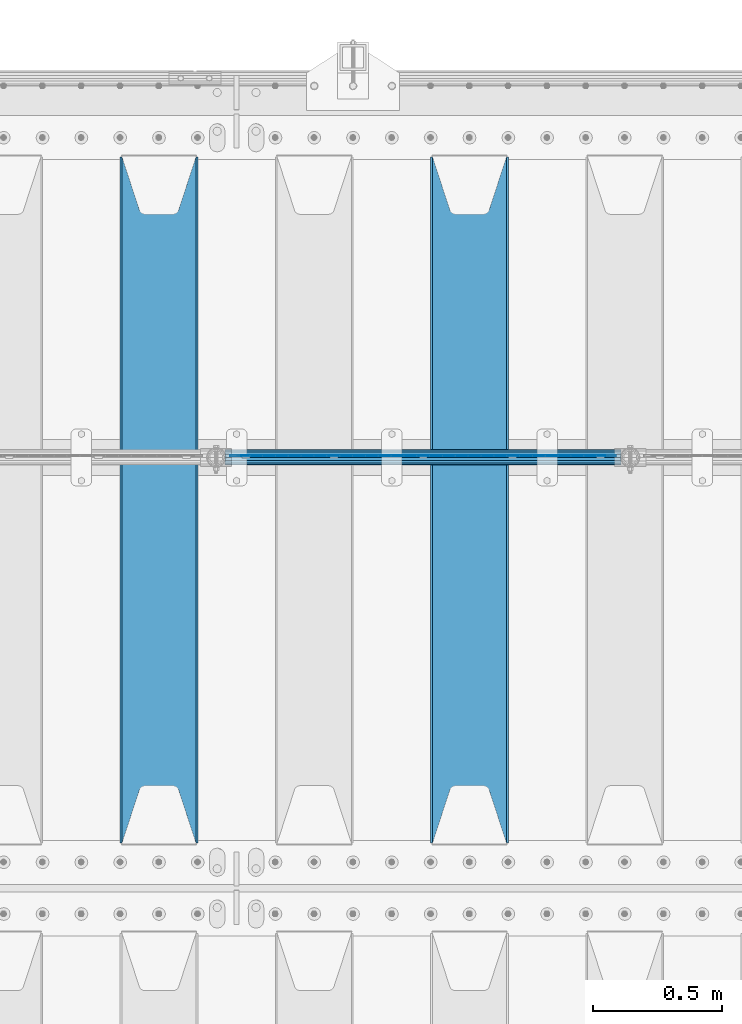
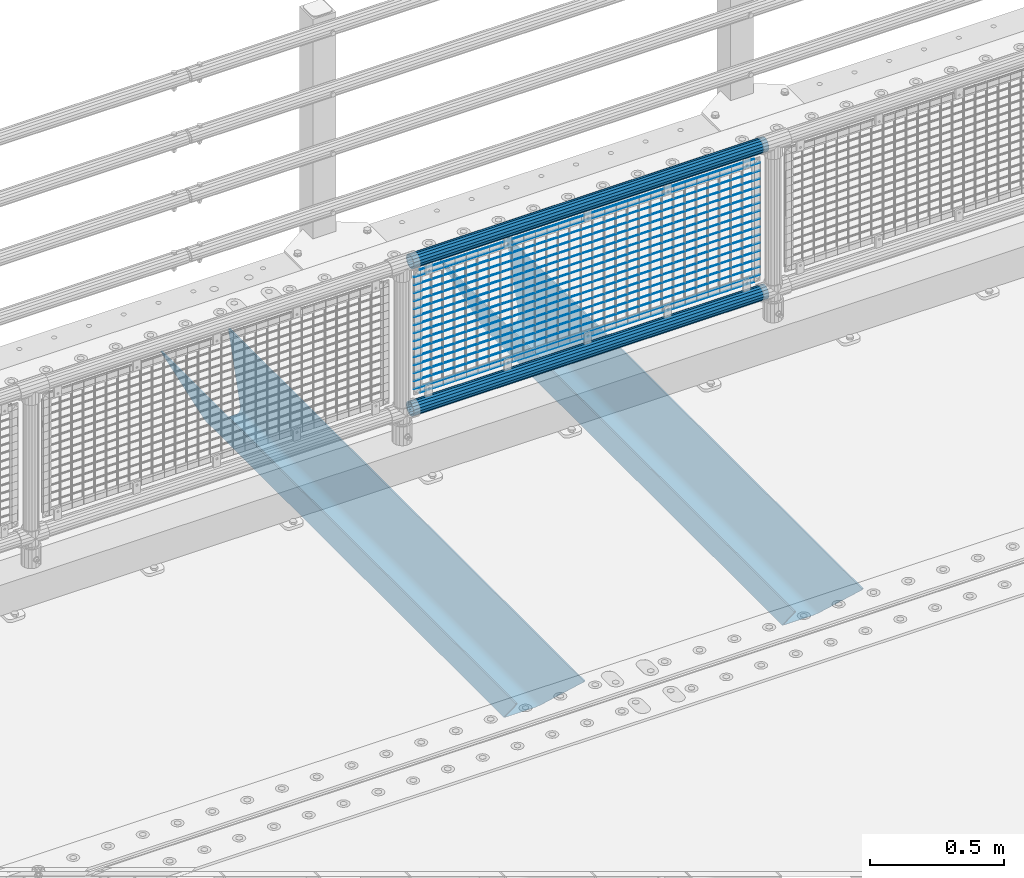
# One storey, part 119 of 257: 21 beams.
"""IFC2X3 building model written with IfcOpenShell, lengths in millimetres."""

from ifc_helpers import new_model, si_unit, frame, origin_with_axes, place, context, subcontext, project, spatial, faceted_brep, material, type_object, element, save


model = new_model("IFC2X3")

# Units and contexts
model_context = context("Model", 3, precision=1e-05, world=origin_with_axes())
body_context = subcontext(model_context, "Body", "Model", "MODEL_VIEW")
ifc_project = project(units=[si_unit("LENGTHUNIT", "METRE", prefix="MILLI"), si_unit("AREAUNIT", "SQUARE_METRE"), si_unit("VOLUMEUNIT", "CUBIC_METRE"), si_unit("MASSUNIT", "GRAM", prefix="KILO"), si_unit("TIMEUNIT", "SECOND"), si_unit("PLANEANGLEUNIT", "RADIAN"), si_unit("SOLIDANGLEUNIT", "STERADIAN"), si_unit("THERMODYNAMICTEMPERATUREUNIT", "DEGREE_CELSIUS"), si_unit("LUMINOUSINTENSITYUNIT", "LUMEN")], contexts=[model_context])

# Site, building, storey
site_placement = place(None, origin_with_axes())
site = spatial("IfcSite", under=ifc_project, at=site_placement, CompositionType="ELEMENT")
building_placement = place(site_placement, origin_with_axes())
building = spatial("IfcBuilding", under=site, at=building_placement, Name="Standard", CompositionType="ELEMENT")
storey_placement = place(building_placement, origin_with_axes())
storey = spatial("IfcBuildingStorey", under=building, at=storey_placement, Name="Undefined", CompositionType="ELEMENT", Elevation=0.0)

# Beams
ifc_material_1 = material(Name="STEEL/S355N")
beam_type_1 = type_object("IfcBeamType", PredefinedType="NOTDEFINED")
beam_1_placement = place(storey_placement, frame((48850.0, 9175.0, -115.0), z_axis=(0.0, 0.0, 1.0), x_axis=(0.0, 1.0, 0.0)))
element("IfcBeam", 1, at=beam_1_placement, inside=storey, type_object=beam_type_1, material=ifc_material_1, context=body_context, shape_type="Brep", body=[
    faceted_brep([(0.0, 150.0, 115.0), (0.0, 143.690000000002, 115.0), (2650.00000000297, 143.690000000002, 115.0), (2650.00000000297, 150.0, 115.0), (2650.00000000297, 142.059565218406, 110.0000000031), (2650.00000000297, 148.369565218403, 110.0000000031), (2441.90079219208, -80.1103600731149, -98.0992078077845), (2437.7588105432, -77.5672621345584, -102.241189456673), (2434.06523489746, -74.4080125315522, -105.934765102404), (2430.91086095089, -70.7102721255724, -109.089139048974), (2428.37322971128, -66.5649389910031, -111.626770288588), (2426.51472138055, -62.0739139532889, -113.485278619323), (2425.38102192091, -57.3475956567636, -114.618978078955), (2424.99999999987, -52.5021667386536, -115.0), (2424.99999999987, 52.5021667386536, -115.0), (2425.38102192091, 57.3475956567636, -114.618978078955), (2426.51472138055, 62.0739139532889, -113.485278619323), (2428.37322971128, 66.5649389910031, -111.626770288588), (2430.91086095089, 70.7102721255724, -109.089139048974), (2434.06523489746, 74.4080125315522, -105.934765102404), (2437.7588105432, 77.5672621345584, -102.241189456673), (2441.90079219208, 80.1103600731149, -98.0992078077846), (2446.38936140511, 81.9747917625791, -93.6106385947584), (2448.24948500409, 76.2713538057287, -91.7505149957729), (2444.62967112262, 74.76777986261, -95.3703288772456), (2441.28936334126, 72.7168944282894, -98.710636658607), (2438.31067330438, 70.1691124903809, -101.689326695487), (2435.76682334747, 67.1870637758839, -104.233176652398), (2433.72034654133, 63.8440531834931, -106.279653458539), (2432.22154950041, 60.2222587982324, -107.778450499454), (2431.30727574265, 56.4107117849126, -108.692724257221), (2430.99999999987, 52.5031078186876, -109.0), (2430.99999999987, -52.5031078186876, -109.0), (2431.30727574265, -56.4107117849126, -108.692724257221), (2432.22154950041, -60.2222587982324, -107.778450499454), (2433.72034654133, -63.8440531834931, -106.279653458539), (2435.76682334747, -67.1870637758839, -104.233176652398), (2438.31067330438, -70.1691124903809, -101.689326695487), (2441.28936334126, -72.7168944282894, -98.7106366586071), (2444.62967112262, -74.76777986261, -95.3703288772457), (2448.24948500409, -76.2713538057287, -91.7505149957729), (2650.00000000297, -142.059565218406, 110.0000000031), (2650.00000000297, -148.369565218403, 110.0000000031), (2446.38936140511, -81.9747917625791, -93.6106385947584), (2650.00000000297, -143.690000000002, 115.0), (2650.00000000297, -150.0, 115.0), (0.0, -143.690000000002, 115.0), (0.0, -150.0, 115.0), (0.0, -148.369565218258, 110.000000002662), (203.61063859742, -81.9747917625791, -93.6106385947584), (208.099207810447, -80.1103600731149, -98.0992078077845), (212.241189459335, -77.5672621345584, -102.241189456673), (215.934765105066, -74.4080125315522, -105.934765102404), (219.089139051636, -70.7102721255724, -109.089139048974), (221.626770291251, -66.5649389910031, -111.626770288588), (223.485278621985, -62.0739139532889, -113.485278619323), (224.618978081617, -57.3475956567636, -114.618978078955), (225.000000002662, -52.5021667386536, -115.0), (225.000000002662, 52.5021667386536, -115.0), (224.618978081617, 57.3475956567636, -114.618978078955), (223.485278621985, 62.0739139532889, -113.485278619323), (221.626770291251, 66.5649389910031, -111.626770288588), (219.089139051636, 70.7102721255724, -109.089139048974), (215.934765105066, 74.4080125315522, -105.934765102404), (212.241189459335, 77.5672621345584, -102.241189456673), (208.099207810447, 80.1103600731149, -98.0992078077846), (203.61063859742, 81.9747917625791, -93.6106385947584), (0.0, 148.369565218258, 110.000000002662), (0.0, 142.05956521826, 110.000000002662), (201.750514998435, 76.2713538057287, -91.7505149957729), (205.370328879908, 74.76777986261, -95.3703288772456), (208.710636661269, 72.7168944282894, -98.710636658607), (211.689326698149, 70.1691124903809, -101.689326695487), (214.233176655061, 67.1870637758839, -104.233176652398), (216.279653461201, 63.8440531834931, -106.279653458539), (217.778450502116, 60.2222587982324, -107.778450499454), (218.692724259884, 56.4107117849126, -108.692724257221), (219.000000002662, 52.5031078186876, -109.0), (219.000000002662, -52.5031078186876, -109.0), (218.692724259884, -56.4107117849126, -108.692724257221), (217.778450502116, -60.2222587982324, -107.778450499454), (216.279653461201, -63.8440531834931, -106.279653458539), (214.233176655061, -67.1870637758839, -104.233176652398), (211.689326698149, -70.1691124903809, -101.689326695487), (208.710636661269, -72.7168944282894, -98.7106366586071), (205.370328879908, -74.76777986261, -95.3703288772457), (201.750514998435, -76.2713538057287, -91.7505149957729), (0.0, -142.05956521826, 110.000000002662)], [[[0, 1, 2, 3]], [[3, 2, 4, 5]], [[6, 7, 8, 9, 10, 11, 12, 13, 14, 15, 16, 17, 18, 19, 20, 21, 22, 5, 4, 23, 24, 25, 26, 27, 28, 29, 30, 31, 32, 33, 34, 35, 36, 37, 38, 39, 40, 41, 42, 43]], [[44, 45, 42, 41]], [[46, 47, 45, 44]], [[43, 42, 45, 47, 48, 49]], [[6, 43, 49, 50]], [[7, 6, 50, 51]], [[8, 7, 51, 52]], [[9, 8, 52, 53]], [[10, 9, 53, 54]], [[11, 10, 54, 55]], [[12, 11, 55, 56]], [[13, 12, 56, 57]], [[14, 13, 57, 58]], [[15, 14, 58, 59]], [[16, 15, 59, 60]], [[17, 16, 60, 61]], [[18, 17, 61, 62]], [[19, 18, 62, 63]], [[20, 19, 63, 64]], [[21, 20, 64, 65]], [[22, 21, 65, 66]], [[0, 3, 5, 22, 66, 67]], [[1, 0, 67, 68]], [[23, 4, 2, 1, 68, 69]], [[24, 23, 69, 70]], [[25, 24, 70, 71]], [[26, 25, 71, 72]], [[27, 26, 72, 73]], [[28, 27, 73, 74]], [[29, 28, 74, 75]], [[30, 29, 75, 76]], [[31, 30, 76, 77]], [[32, 31, 77, 78]], [[33, 32, 78, 79]], [[34, 33, 79, 80]], [[35, 34, 80, 81]], [[36, 35, 81, 82]], [[37, 36, 82, 83]], [[38, 37, 83, 84]], [[39, 38, 84, 85]], [[40, 39, 85, 86]], [[46, 44, 41, 40, 86, 87]], [[47, 46, 87, 48]], [[86, 85, 84, 83, 82, 81, 80, 79, 78, 77, 76, 75, 74, 73, 72, 71, 70, 69, 68, 67, 66, 65, 64, 63, 62, 61, 60, 59, 58, 57, 56, 55, 54, 53, 52, 51, 50, 49, 48, 87]]]),
])
beam_2_placement = place(storey_placement, frame((47650.0, 9175.0, -115.0), z_axis=(0.0, 0.0, 1.0), x_axis=(0.0, 1.0, 0.0)))
element("IfcBeam", 2, at=beam_2_placement, inside=storey, type_object=beam_type_1, material=ifc_material_1, context=body_context, shape_type="Brep", body=[
    faceted_brep([(0.0, 150.0, 115.0), (0.0, 143.690000000002, 115.0), (2650.00000000297, 143.690000000002, 115.0), (2650.00000000297, 150.0, 115.0), (2650.00000000297, 142.059565218406, 110.0000000031), (2650.00000000297, 148.369565218403, 110.0000000031), (2441.90079219208, -80.1103600731149, -98.0992078077845), (2437.7588105432, -77.5672621345584, -102.241189456673), (2434.06523489746, -74.4080125315522, -105.934765102404), (2430.91086095089, -70.7102721255724, -109.089139048974), (2428.37322971128, -66.5649389910031, -111.626770288588), (2426.51472138055, -62.0739139532889, -113.485278619323), (2425.38102192091, -57.3475956567636, -114.618978078955), (2424.99999999987, -52.5021667386536, -115.0), (2424.99999999987, 52.5021667386536, -115.0), (2425.38102192091, 57.3475956567636, -114.618978078955), (2426.51472138055, 62.0739139532889, -113.485278619323), (2428.37322971128, 66.5649389910031, -111.626770288588), (2430.91086095089, 70.7102721255724, -109.089139048974), (2434.06523489746, 74.4080125315522, -105.934765102404), (2437.7588105432, 77.5672621345584, -102.241189456673), (2441.90079219208, 80.1103600731149, -98.0992078077846), (2446.38936140511, 81.9747917625791, -93.6106385947584), (2448.24948500409, 76.2713538057287, -91.7505149957729), (2444.62967112262, 74.76777986261, -95.3703288772456), (2441.28936334126, 72.7168944282894, -98.710636658607), (2438.31067330438, 70.1691124903809, -101.689326695487), (2435.76682334747, 67.1870637758839, -104.233176652398), (2433.72034654133, 63.8440531834931, -106.279653458539), (2432.22154950041, 60.2222587982324, -107.778450499454), (2431.30727574265, 56.4107117849126, -108.692724257221), (2430.99999999987, 52.5031078186876, -109.0), (2430.99999999987, -52.5031078186876, -109.0), (2431.30727574265, -56.4107117849126, -108.692724257221), (2432.22154950041, -60.2222587982324, -107.778450499454), (2433.72034654133, -63.8440531834931, -106.279653458539), (2435.76682334747, -67.1870637758839, -104.233176652398), (2438.31067330438, -70.1691124903809, -101.689326695487), (2441.28936334126, -72.7168944282894, -98.7106366586071), (2444.62967112262, -74.76777986261, -95.3703288772457), (2448.24948500409, -76.2713538057287, -91.7505149957729), (2650.00000000297, -142.059565218406, 110.0000000031), (2650.00000000297, -148.369565218403, 110.0000000031), (2446.38936140511, -81.9747917625791, -93.6106385947584), (2650.00000000297, -143.690000000002, 115.0), (2650.00000000297, -150.0, 115.0), (0.0, -143.690000000002, 115.0), (0.0, -150.0, 115.0), (0.0, -148.369565218258, 110.000000002662), (203.61063859742, -81.9747917625791, -93.6106385947584), (208.099207810447, -80.1103600731149, -98.0992078077845), (212.241189459335, -77.5672621345584, -102.241189456673), (215.934765105066, -74.4080125315522, -105.934765102404), (219.089139051636, -70.7102721255724, -109.089139048974), (221.626770291251, -66.5649389910031, -111.626770288588), (223.485278621985, -62.0739139532889, -113.485278619323), (224.618978081617, -57.3475956567636, -114.618978078955), (225.000000002662, -52.5021667386536, -115.0), (225.000000002662, 52.5021667386536, -115.0), (224.618978081617, 57.3475956567636, -114.618978078955), (223.485278621985, 62.0739139532889, -113.485278619323), (221.626770291251, 66.5649389910031, -111.626770288588), (219.089139051636, 70.7102721255724, -109.089139048974), (215.934765105066, 74.4080125315522, -105.934765102404), (212.241189459335, 77.5672621345584, -102.241189456673), (208.099207810447, 80.1103600731149, -98.0992078077846), (203.61063859742, 81.9747917625791, -93.6106385947584), (0.0, 148.369565218258, 110.000000002662), (0.0, 142.05956521826, 110.000000002662), (201.750514998435, 76.2713538057287, -91.7505149957729), (205.370328879908, 74.76777986261, -95.3703288772456), (208.710636661269, 72.7168944282894, -98.710636658607), (211.689326698149, 70.1691124903809, -101.689326695487), (214.233176655061, 67.1870637758839, -104.233176652398), (216.279653461201, 63.8440531834931, -106.279653458539), (217.778450502116, 60.2222587982324, -107.778450499454), (218.692724259884, 56.4107117849126, -108.692724257221), (219.000000002662, 52.5031078186876, -109.0), (219.000000002662, -52.5031078186876, -109.0), (218.692724259884, -56.4107117849126, -108.692724257221), (217.778450502116, -60.2222587982324, -107.778450499454), (216.279653461201, -63.8440531834931, -106.279653458539), (214.233176655061, -67.1870637758839, -104.233176652398), (211.689326698149, -70.1691124903809, -101.689326695487), (208.710636661269, -72.7168944282894, -98.7106366586071), (205.370328879908, -74.76777986261, -95.3703288772457), (201.750514998435, -76.2713538057287, -91.7505149957729), (0.0, -142.05956521826, 110.000000002662)], [[[0, 1, 2, 3]], [[3, 2, 4, 5]], [[6, 7, 8, 9, 10, 11, 12, 13, 14, 15, 16, 17, 18, 19, 20, 21, 22, 5, 4, 23, 24, 25, 26, 27, 28, 29, 30, 31, 32, 33, 34, 35, 36, 37, 38, 39, 40, 41, 42, 43]], [[44, 45, 42, 41]], [[46, 47, 45, 44]], [[43, 42, 45, 47, 48, 49]], [[6, 43, 49, 50]], [[7, 6, 50, 51]], [[8, 7, 51, 52]], [[9, 8, 52, 53]], [[10, 9, 53, 54]], [[11, 10, 54, 55]], [[12, 11, 55, 56]], [[13, 12, 56, 57]], [[14, 13, 57, 58]], [[15, 14, 58, 59]], [[16, 15, 59, 60]], [[17, 16, 60, 61]], [[18, 17, 61, 62]], [[19, 18, 62, 63]], [[20, 19, 63, 64]], [[21, 20, 64, 65]], [[22, 21, 65, 66]], [[0, 3, 5, 22, 66, 67]], [[1, 0, 67, 68]], [[23, 4, 2, 1, 68, 69]], [[24, 23, 69, 70]], [[25, 24, 70, 71]], [[26, 25, 71, 72]], [[27, 26, 72, 73]], [[28, 27, 73, 74]], [[29, 28, 74, 75]], [[30, 29, 75, 76]], [[31, 30, 76, 77]], [[32, 31, 77, 78]], [[33, 32, 78, 79]], [[34, 33, 79, 80]], [[35, 34, 80, 81]], [[36, 35, 81, 82]], [[37, 36, 82, 83]], [[38, 37, 83, 84]], [[39, 38, 84, 85]], [[40, 39, 85, 86]], [[46, 44, 41, 40, 86, 87]], [[47, 46, 87, 48]], [[86, 85, 84, 83, 82, 81, 80, 79, 78, 77, 76, 75, 74, 73, 72, 71, 70, 69, 68, 67, 66, 65, 64, 63, 62, 61, 60, 59, 58, 57, 56, 55, 54, 53, 52, 51, 50, 49, 48, 87]]]),
])
ifc_material_2 = material(Name="Misc_Undefined")
beam_type_2 = type_object("IfcBeamType", Name="D3", PredefinedType="NOTDEFINED")
for number, where, z_axis, x_axis in (
    (3, (47926.0, 10670.5, 851.597000000001), (0.0, 0.0, 1.0), (1.0, 0.0, 0.0)),
    (4, (47926.0, 10670.5, 669.452000000001), (0.0, 0.0, 1.0), (1.0, 0.0, 0.0)),
    (5, (47926.0, 10670.5, 523.736000000001), (0.0, 0.0, 1.0), (1.0, 0.0, 0.0)),
    (6, (47926.0, 10670.5, 487.307000000001), (0.0, 0.0, 1.0), (1.0, 0.0, 0.0)),
    (7, (47926.0, 10670.5, 705.881000000001), (0.0, 0.0, 1.0), (1.0, 0.0, 0.0)),
    (8, (47926.0, 10670.5, 596.594000000001), (0.0, 0.0, 1.0), (1.0, 0.0, 0.0)),
    (9, (47926.0, 10670.5, 450.878000000001), (0.0, 0.0, 1.0), (1.0, 0.0, 0.0)),
    (10, (47926.0, 10670.5, 815.168000000001), (0.0, 0.0, 1.0), (1.0, 0.0, 0.0)),
    (11, (47926.0, 10670.5, 888.026000000001), (0.0, 0.0, 1.0), (1.0, 0.0, 0.0)),
    (12, (47926.0, 10670.5, 778.739000000001), (0.0, 0.0, 1.0), (1.0, 0.0, 0.0)),
    (13, (47926.0, 10670.5, 742.310000000001), (0.0, 0.0, 1.0), (1.0, 0.0, 0.0)),
    (14, (47926.0, 10670.5, 633.023000000001), (0.0, 0.0, 1.0), (1.0, 0.0, 0.0)),
    (15, (47926.0, 10670.5, 560.165000000001), (0.0, 0.0, 1.0), (1.0, 0.0, 0.0)),
    (16, (47926.0, 10670.5, 414.449000000001), (0.0, 0.0, 1.0), (1.0, 0.0, 0.0)),
):
    element("IfcBeam", number, at=place(storey_placement, frame(where, z_axis=z_axis, x_axis=x_axis)), inside=storey, type_object=beam_type_2, material=ifc_material_2, ObjectType="D3", context=body_context, shape_type="Brep", body=[
        faceted_brep([(0.0, -1.5, -5.6843418860808e-14), (0.0, -0.750000000001819, -1.29903810567669), (1490.0, -0.75, -1.29903810567669), (1490.0, -1.5, 0.0), (7.27595761418343e-12, 0.749999999998181, -1.29903810567669), (1490.0, 0.75, -1.29903810567669), (0.0, 1.5, -5.6843418860808e-14), (1490.0, 1.5, 0.0), (7.27595761418343e-12, 0.749999999998181, 1.29903810567669), (1490.0, 0.75, 1.29903810567669), (0.0, -0.750000000001819, 1.29903810567669), (1490.0, -0.75, 1.29903810567669)], [[[0, 1, 2, 3]], [[1, 4, 5, 2]], [[4, 6, 7, 5]], [[6, 8, 9, 7]], [[8, 10, 11, 9]], [[10, 0, 3, 11]], [[5, 7, 9, 11, 3, 2]], [[10, 8, 6, 4, 1, 0]]]),
    ])
beam_3_placement = place(storey_placement, frame((47951.0, 10670.5, 353.020000000001), z_axis=(0.0, 0.0, 1.0), x_axis=(1.0, 0.0, 0.0)))
element("IfcBeam", 17, at=beam_3_placement, inside=storey, type_object=beam_type_2, material=ifc_material_2, ObjectType="D3", context=body_context, shape_type="Brep", body=[
    faceted_brep([(0.0, -1.5, -5.6843418860808e-14), (0.0, -0.750000000001819, -1.29903810567669), (1440.0, -0.75, -1.29903810567669), (1440.0, -1.5, 0.0), (7.27595761418343e-12, 0.749999999998181, -1.29903810567669), (1440.0, 0.75, -1.29903810567663), (0.0, 1.5, -5.6843418860808e-14), (1440.0, 1.5, 0.0), (7.27595761418343e-12, 0.749999999998181, 1.29903810567669), (1440.0, 0.75, 1.29903810567669), (0.0, -0.750000000001819, 1.29903810567669), (1440.0, -0.75, 1.29903810567669)], [[[0, 1, 2, 3]], [[1, 4, 5, 2]], [[4, 6, 7, 5]], [[6, 8, 9, 7]], [[8, 10, 11, 9]], [[10, 0, 3, 11]], [[5, 7, 9, 11, 3, 2]], [[10, 8, 6, 4, 1, 0]]]),
])
beam_4_placement = place(storey_placement, frame((47926.0, 10670.5, 378.020000000001), z_axis=(0.0, 0.0, 1.0), x_axis=(1.0, 0.0, 0.0)))
element("IfcBeam", 18, at=beam_4_placement, inside=storey, type_object=beam_type_2, material=ifc_material_2, ObjectType="D3", context=body_context, shape_type="Brep", body=[
    faceted_brep([(0.0, -1.5, -5.6843418860808e-14), (0.0, -0.750000000001819, -1.29903810567669), (1490.0, -0.75, -1.29903810567669), (1490.0, -1.5, 0.0), (7.27595761418343e-12, 0.749999999998181, -1.29903810567669), (1490.0, 0.75, -1.29903810567669), (0.0, 1.5, -5.6843418860808e-14), (1490.0, 1.5, 0.0), (7.27595761418343e-12, 0.749999999998181, 1.29903810567669), (1490.0, 0.75, 1.29903810567669), (0.0, -0.750000000001819, 1.29903810567669), (1490.0, -0.75, 1.29903810567669)], [[[0, 1, 2, 3]], [[1, 4, 5, 2]], [[4, 6, 7, 5]], [[6, 8, 9, 7]], [[8, 10, 11, 9]], [[10, 0, 3, 11]], [[5, 7, 9, 11, 3, 2]], [[10, 8, 6, 4, 1, 0]]]),
])
beam_5_placement = place(storey_placement, frame((47951.0, 10670.5, 913.020000000001), z_axis=(0.0, 0.0, 1.0), x_axis=(1.0, 0.0, 0.0)))
element("IfcBeam", 19, at=beam_5_placement, inside=storey, type_object=beam_type_2, material=ifc_material_2, ObjectType="D3", context=body_context, shape_type="Brep", body=[
    faceted_brep([(0.0, -1.5, -5.6843418860808e-14), (0.0, -0.750000000001819, -1.29903810567669), (1440.0, -0.75, -1.29903810567669), (1440.0, -1.5, 0.0), (7.27595761418343e-12, 0.749999999998181, -1.29903810567669), (1440.0, 0.75, -1.29903810567663), (0.0, 1.5, -5.6843418860808e-14), (1440.0, 1.5, 0.0), (7.27595761418343e-12, 0.749999999998181, 1.29903810567669), (1440.0, 0.75, 1.29903810567669), (0.0, -0.750000000001819, 1.29903810567669), (1440.0, -0.75, 1.29903810567669)], [[[0, 1, 2, 3]], [[1, 4, 5, 2]], [[4, 6, 7, 5]], [[6, 8, 9, 7]], [[8, 10, 11, 9]], [[10, 0, 3, 11]], [[5, 7, 9, 11, 3, 2]], [[10, 8, 6, 4, 1, 0]]]),
])
ifc_material_3 = material()
beam_type_3 = type_object("IfcBeamType", PredefinedType="NOTDEFINED")
beam_6_placement = place(storey_placement, frame((47905.85, 10664.5, 298.170000000003), z_axis=(0.0, 0.0, 1.0), x_axis=(1.0, 0.0, 0.0)))
element("IfcBeam", 20, at=beam_6_placement, inside=storey, type_object=beam_type_3, material=ifc_material_3, context=body_context, shape_type="Brep", body=[
    faceted_brep([(0.0, -25.3500000000004, 0.0), (0.0, -23.4203461491616, 9.70102501045767), (1530.0, -23.4203461491616, 9.70102501045506), (1530.0, -25.3500000000004, 0.0), (0.0, -17.9251569030785, 17.9251569030821), (1530.0, -17.9251569030785, 17.925156903079), (0.0, -9.70102501045585, 23.4203461491634), (1530.0, -9.70102501045585, 23.4203461491611), (0.0, 0.0, 25.3499999999985), (1530.0, 0.0, 25.35), (0.0, 9.70102501045585, 23.4203461491634), (1530.0, 9.70102501045585, 23.4203461491611), (0.0, 17.9251569030785, 17.9251569030821), (1530.0, 17.9251569030785, 17.925156903079), (0.0, 23.4203461491616, 9.70102501045767), (1530.0, 23.4203461491616, 9.701025010455), (0.0, 25.3500000000004, 0.0), (1530.0, 25.3500000000004, 0.0), (0.0, 23.4203461491616, -9.70102501045767), (1530.0, 23.4203461491616, -9.70102501045506), (0.0, 17.9251569030785, -17.9251569030821), (1530.0, 17.9251569030785, -17.925156903079), (0.0, 9.70102501045585, -23.4203461491634), (1530.0, 9.70102501045585, -23.4203461491611), (0.0, 0.0, -25.3499999999985), (1530.0, 0.0, -25.35), (0.0, -9.70102501045585, -23.4203461491634), (1530.0, -9.70102501045585, -23.4203461491611), (0.0, -17.9251569030785, -17.9251569030821), (1530.0, -17.9251569030785, -17.925156903079), (0.0, -23.4203461491616, -9.70102501045767), (1530.0, -23.4203461491616, -9.701025010455), (0.0, -30.1499999999996, 0.0), (0.0, -27.8549679052157, -11.5379054858058), (1530.0, -27.8549679052157, -11.5379054858075), (1530.0, -30.1499999999996, 0.0), (0.0, -21.3192694527752, -21.3192694527752), (1530.0, -21.3192694527752, -21.3192694527744), (0.0, -11.5379054858076, -27.8549679052157), (1530.0, -11.5379054858076, -27.8549679052153), (0.0, 0.0, -30.1500000000015), (1530.0, 0.0, -30.15), (0.0, 11.5379054858076, -27.8549679052157), (1530.0, 11.5379054858076, -27.8549679052153), (0.0, 21.3192694527752, -21.3192694527752), (1530.0, 21.3192694527752, -21.3192694527744), (0.0, 27.8549679052157, -11.5379054858058), (1530.0, 27.8549679052157, -11.5379054858075), (0.0, 30.1499999999996, 0.0), (1530.0, 30.1499999999996, 0.0), (0.0, 27.8549679052157, 11.5379054858058), (1530.0, 27.8549679052157, 11.5379054858075), (0.0, 21.3192694527752, 21.3192694527752), (1530.0, 21.3192694527752, 21.3192694527744), (0.0, 11.5379054858076, 27.8549679052157), (1530.0, 11.5379054858076, 27.8549679052153), (0.0, 0.0, 30.1500000000015), (1530.0, 0.0, 30.15), (0.0, -11.5379054858076, 27.8549679052157), (1530.0, -11.5379054858076, 27.8549679052153), (0.0, -21.3192694527752, 21.3192694527752), (1530.0, -21.3192694527752, 21.3192694527744), (0.0, -27.8549679052157, 11.5379054858058), (1530.0, -27.8549679052157, 11.5379054858075)], [[[0, 1, 2, 3]], [[1, 4, 5, 2]], [[4, 6, 7, 5]], [[6, 8, 9, 7]], [[8, 10, 11, 9]], [[10, 12, 13, 11]], [[12, 14, 15, 13]], [[14, 16, 17, 15]], [[16, 18, 19, 17]], [[18, 20, 21, 19]], [[20, 22, 23, 21]], [[22, 24, 25, 23]], [[24, 26, 27, 25]], [[26, 28, 29, 27]], [[28, 30, 31, 29]], [[30, 0, 3, 31]], [[32, 33, 34, 35]], [[33, 36, 37, 34]], [[36, 38, 39, 37]], [[38, 40, 41, 39]], [[40, 42, 43, 41]], [[42, 44, 45, 43]], [[44, 46, 47, 45]], [[46, 48, 49, 47]], [[48, 50, 51, 49]], [[50, 52, 53, 51]], [[52, 54, 55, 53]], [[54, 56, 57, 55]], [[56, 58, 59, 57]], [[58, 60, 61, 59]], [[60, 62, 63, 61]], [[62, 32, 35, 63]], [[37, 39, 41, 43, 45, 47, 49, 51, 53, 55, 57, 59, 61, 63, 35, 34], [5, 7, 9, 11, 13, 15, 17, 19, 21, 23, 25, 27, 29, 31, 3, 2]], [[62, 60, 58, 56, 54, 52, 50, 48, 46, 44, 42, 40, 38, 36, 33, 32], [30, 28, 26, 24, 22, 20, 18, 16, 14, 12, 10, 8, 6, 4, 1, 0]]]),
])
beam_7_placement = place(storey_placement, frame((47905.85, 10664.5, 969.850000000001), z_axis=(0.0, 0.0, 1.0), x_axis=(1.0, 0.0, 0.0)))
element("IfcBeam", 21, at=beam_7_placement, inside=storey, type_object=beam_type_3, material=ifc_material_3, context=body_context, shape_type="Brep", body=[
    faceted_brep([(0.0, -25.3500000000004, 0.0), (0.0, -23.4203461491616, 9.70102501045767), (1530.0, -23.4203461491616, 9.70102501045506), (1530.0, -25.3500000000004, 0.0), (0.0, -17.9251569030785, 17.9251569030821), (1530.0, -17.9251569030785, 17.925156903079), (0.0, -9.70102501045585, 23.4203461491634), (1530.0, -9.70102501045585, 23.4203461491611), (0.0, 0.0, 25.3499999999985), (1530.0, 0.0, 25.35), (0.0, 9.70102501045585, 23.4203461491634), (1530.0, 9.70102501045585, 23.4203461491611), (0.0, 17.9251569030785, 17.9251569030821), (1530.0, 17.9251569030785, 17.925156903079), (0.0, 23.4203461491616, 9.70102501045767), (1530.0, 23.4203461491616, 9.701025010455), (0.0, 25.3500000000004, 0.0), (1530.0, 25.3500000000004, 0.0), (0.0, 23.4203461491616, -9.70102501045767), (1530.0, 23.4203461491616, -9.70102501045506), (0.0, 17.9251569030785, -17.9251569030821), (1530.0, 17.9251569030785, -17.925156903079), (0.0, 9.70102501045585, -23.4203461491634), (1530.0, 9.70102501045585, -23.4203461491611), (0.0, 0.0, -25.3499999999985), (1530.0, 0.0, -25.35), (0.0, -9.70102501045585, -23.4203461491634), (1530.0, -9.70102501045585, -23.4203461491611), (0.0, -17.9251569030785, -17.9251569030821), (1530.0, -17.9251569030785, -17.925156903079), (0.0, -23.4203461491616, -9.70102501045767), (1530.0, -23.4203461491616, -9.701025010455), (0.0, -30.1499999999996, 0.0), (0.0, -27.8549679052157, -11.5379054858058), (1530.0, -27.8549679052157, -11.5379054858075), (1530.0, -30.1499999999996, 0.0), (0.0, -21.3192694527752, -21.3192694527752), (1530.0, -21.3192694527752, -21.3192694527744), (0.0, -11.5379054858076, -27.8549679052157), (1530.0, -11.5379054858076, -27.8549679052153), (0.0, 0.0, -30.1500000000015), (1530.0, 0.0, -30.15), (0.0, 11.5379054858076, -27.8549679052157), (1530.0, 11.5379054858076, -27.8549679052153), (0.0, 21.3192694527752, -21.3192694527752), (1530.0, 21.3192694527752, -21.3192694527744), (0.0, 27.8549679052157, -11.5379054858058), (1530.0, 27.8549679052157, -11.5379054858075), (0.0, 30.1499999999996, 0.0), (1530.0, 30.1499999999996, 0.0), (0.0, 27.8549679052157, 11.5379054858058), (1530.0, 27.8549679052157, 11.5379054858075), (0.0, 21.3192694527752, 21.3192694527752), (1530.0, 21.3192694527752, 21.3192694527744), (0.0, 11.5379054858076, 27.8549679052157), (1530.0, 11.5379054858076, 27.8549679052153), (0.0, 0.0, 30.1500000000015), (1530.0, 0.0, 30.15), (0.0, -11.5379054858076, 27.8549679052157), (1530.0, -11.5379054858076, 27.8549679052153), (0.0, -21.3192694527752, 21.3192694527752), (1530.0, -21.3192694527752, 21.3192694527744), (0.0, -27.8549679052157, 11.5379054858058), (1530.0, -27.8549679052157, 11.5379054858075)], [[[0, 1, 2, 3]], [[1, 4, 5, 2]], [[4, 6, 7, 5]], [[6, 8, 9, 7]], [[8, 10, 11, 9]], [[10, 12, 13, 11]], [[12, 14, 15, 13]], [[14, 16, 17, 15]], [[16, 18, 19, 17]], [[18, 20, 21, 19]], [[20, 22, 23, 21]], [[22, 24, 25, 23]], [[24, 26, 27, 25]], [[26, 28, 29, 27]], [[28, 30, 31, 29]], [[30, 0, 3, 31]], [[32, 33, 34, 35]], [[33, 36, 37, 34]], [[36, 38, 39, 37]], [[38, 40, 41, 39]], [[40, 42, 43, 41]], [[42, 44, 45, 43]], [[44, 46, 47, 45]], [[46, 48, 49, 47]], [[48, 50, 51, 49]], [[50, 52, 53, 51]], [[52, 54, 55, 53]], [[54, 56, 57, 55]], [[56, 58, 59, 57]], [[58, 60, 61, 59]], [[60, 62, 63, 61]], [[62, 32, 35, 63]], [[37, 39, 41, 43, 45, 47, 49, 51, 53, 55, 57, 59, 61, 63, 35, 34], [5, 7, 9, 11, 13, 15, 17, 19, 21, 23, 25, 27, 29, 31, 3, 2]], [[62, 60, 58, 56, 54, 52, 50, 48, 46, 44, 42, 40, 38, 36, 33, 32], [30, 28, 26, 24, 22, 20, 18, 16, 14, 12, 10, 8, 6, 4, 1, 0]]]),
])

save(model, "model.ifc")
